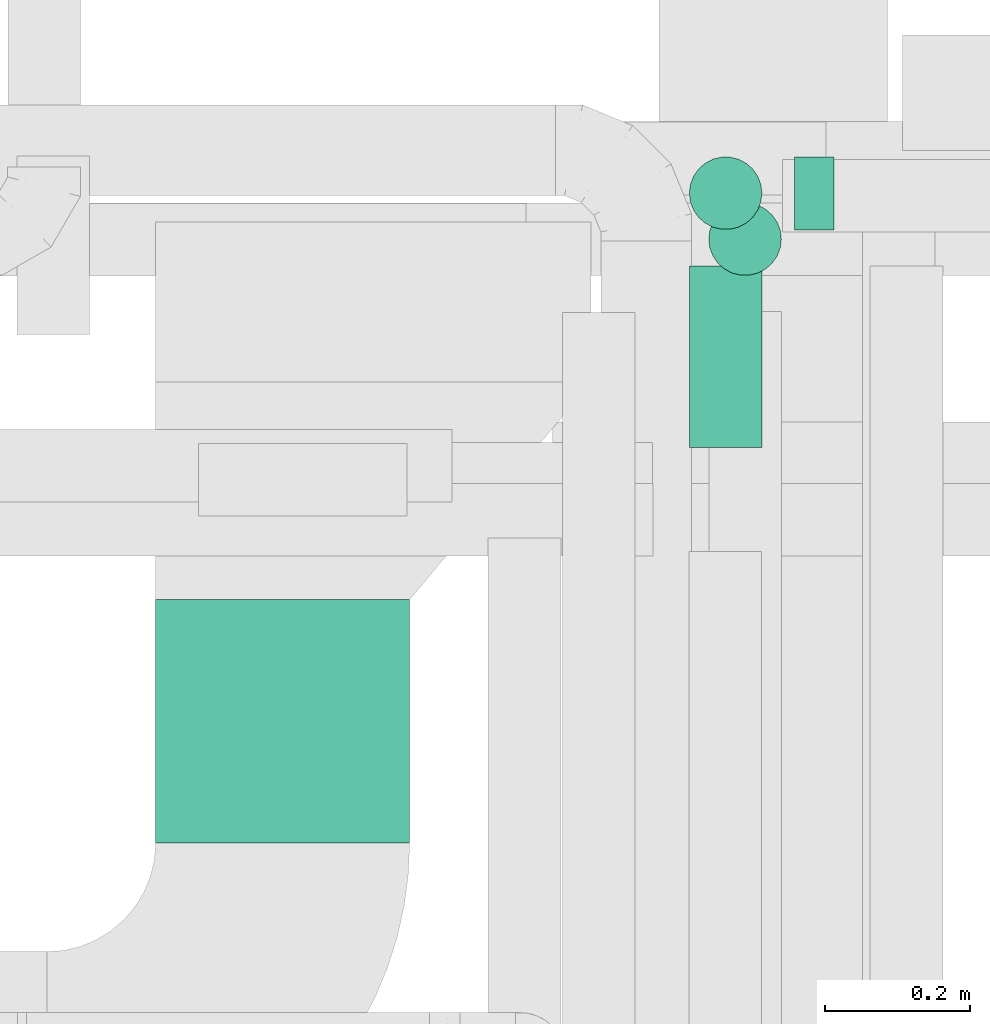
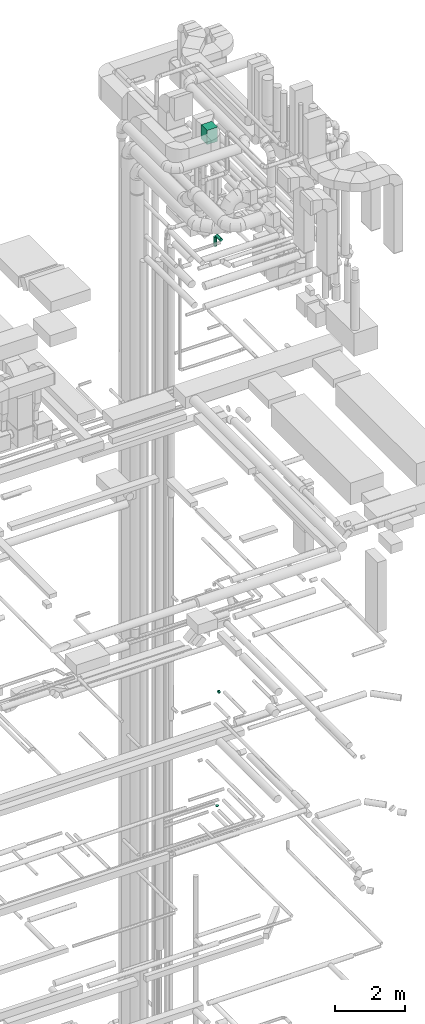
# One storey, part 266 of 337: 5 flow segments.
"""IFC2X3 building model written with IfcOpenShell, lengths in millimetres."""

import ifcopenshell
import ifcopenshell.guid

model = None  # the IFC model being written
_history = None  # IfcOwnerHistory: only IFC2X3 demands one
_inside = {}  # id of a spatial element -> (the spatial element, [elements in it])
_under = {}  # id of a project, library or spatial element -> (it, [spatial elements below it])
_declared = {}  # id of a project -> (the project, [libraries it declares])
_typed = {}  # id of a type object -> (the type object, [elements of that type])
_made_of = {}  # id of a material, layer set ... -> (it, [elements and type objects made of it])


def new_model(schema):
    """Start an empty IFC model of exactly this schema.

    Asked for "IFC4X3", IfcOpenShell would pick the latest addendum, in which some entities
    have other attributes; the version numbers below select the first issue.
    IFC2X3 requires an IfcOwnerHistory on every rooted entity: one is made here for all.
    """
    global model, _history
    if schema == "IFC4X3":
        model = ifcopenshell.file(schema_version=(4, 3, 0, 0))
    else:
        model = ifcopenshell.file(schema=schema)
    _inside.clear()
    _under.clear()
    _declared.clear()
    _typed.clear()
    _made_of.clear()
    _history = None
    if model.schema == "IFC2X3":
        org = make("IfcOrganization", Name="unknown")
        user = make(
            "IfcPersonAndOrganization",
            ThePerson=make("IfcPerson", FamilyName="unknown"),
            TheOrganization=org,
        )
        app = make(
            "IfcApplication",
            ApplicationDeveloper=org,
            Version="unknown",
            ApplicationFullName="unknown",
            ApplicationIdentifier="unknown",
        )
        _history = make(
            "IfcOwnerHistory",
            OwningUser=user,
            OwningApplication=app,
            ChangeAction="ADDED",
            CreationDate=0,
        )
    return model


def make(cls, **values):
    """One entity of the class cls with the attributes given. An attribute that is None is left unset."""
    return model.create_entity(
        cls, **{name: value for name, value in values.items() if value is not None}
    )


def entity(cls, *values):
    """Any entity or typed value of the class cls, its attributes in the order of the schema. None: left unset."""
    e = model.create_entity(cls)
    for i, value in enumerate(values):
        if value is not None:
            e[i] = value
    return e


def rooted(cls, **values):
    """An entity with a GlobalId (a new one), such as an element, a storey or a relation."""
    return make(cls, GlobalId=ifcopenshell.guid.new(), OwnerHistory=_history, **values)


def si_unit(unit_type, name, prefix=None):
    """IfcSIUnit, for example si_unit("LENGTHUNIT", "METRE", prefix="MILLI")."""
    return make("IfcSIUnit", UnitType=unit_type, Prefix=prefix, Name=name)


def converted_unit(unit_type, name, factor, base, dimensions=None, offset=None):
    """IfcConversionBasedUnit, such as the inch: factor (a typed value) times the base unit."""
    return make(
        "IfcConversionBasedUnit"
        if offset is None
        else "IfcConversionBasedUnitWithOffset",
        ConversionOffset=offset,
        Dimensions=None
        if dimensions is None
        else entity("IfcDimensionalExponents", *dimensions),
        UnitType=unit_type,
        Name=name,
        ConversionFactor=make(
            "IfcMeasureWithUnit", ValueComponent=factor, UnitComponent=base
        ),
    )


def derived_unit(unit_type, elements):
    """IfcDerivedUnit: a product of units, each with its exponent."""
    return make(
        "IfcDerivedUnit",
        Elements=[
            make("IfcDerivedUnitElement", Unit=unit, Exponent=power)
            for unit, power in elements
        ],
        UnitType=unit_type,
    )


def assignment(units):
    """IfcUnitAssignment: the units of a project."""
    return None if units is None else make("IfcUnitAssignment", Units=units)


def point(xyz):
    """IfcCartesianPoint."""
    return None if xyz is None else make("IfcCartesianPoint", Coordinates=xyz)


def direction(xyz):
    """IfcDirection."""
    return None if xyz is None else make("IfcDirection", DirectionRatios=xyz)


def frame(location, z_axis=None, x_axis=None):
    """IfcAxis2Placement3D, a coordinate frame: its origin and axes. An axis left out is left unset."""
    return make(
        "IfcAxis2Placement3D",
        Location=point(location),
        Axis=direction(z_axis),
        RefDirection=direction(x_axis),
    )


def frame_2d(location, x_axis=None):
    """IfcAxis2Placement2D, a coordinate frame in the plane: its origin and x axis."""
    return make(
        "IfcAxis2Placement2D", Location=point(location), RefDirection=direction(x_axis)
    )


def origin():
    """The frame at (0, 0, 0) with its axes left unset."""
    return frame((0.0, 0.0, 0.0))


def origin_2d_with_axis():
    """The frame at (0, 0) in the plane with the x axis (1, 0) written out."""
    return frame_2d((0.0, 0.0), x_axis=(1.0, 0.0))


def place(relative_to, where):
    """IfcLocalPlacement: puts the frame where relative to a parent placement (None: the world)."""
    return make(
        "IfcLocalPlacement", PlacementRelTo=relative_to, RelativePlacement=where
    )


def context(
    kind, dimensions, precision=None, world=None, true_north=None, identifier=None
):
    """IfcGeometricRepresentationContext, for example the 3D "Model" context."""
    return make(
        "IfcGeometricRepresentationContext",
        ContextIdentifier=identifier,
        ContextType=kind,
        CoordinateSpaceDimension=dimensions,
        Precision=precision,
        WorldCoordinateSystem=world,
        TrueNorth=true_north,
    )


def subcontext(parent, identifier, kind, view, scale=None):
    """IfcGeometricRepresentationSubContext, for example "Body" below "Model"."""
    return make(
        "IfcGeometricRepresentationSubContext",
        ContextIdentifier=identifier,
        ContextType=kind,
        ParentContext=parent,
        TargetScale=scale,
        TargetView=view,
    )


def project(units=None, contexts=None):
    """IfcProject with its units and contexts."""
    return rooted(
        "IfcProject",
        Name="project",
        RepresentationContexts=contexts,
        UnitsInContext=assignment(units),
    )


def spatial(cls, under=None, at=None, **own):
    """A site, building, storey or space (cls), placed at a placement, below another one or the project."""
    s = rooted(cls, ObjectPlacement=at, **own)
    if under is not None:
        _under.setdefault(under.id(), (under, []))[1].append(s)
    return s


def profile(cls, at=None, kind="AREA", **sizes):
    """A parametric profile (cls). Its sizes go by their IFC names, for example OverallWidth=200.0."""
    return make(cls, ProfileType=kind, Position=at, **sizes)


def rectangle(**sizes):
    """IfcRectangleProfileDef."""
    return profile("IfcRectangleProfileDef", **sizes)


def circle(**sizes):
    """IfcCircleProfileDef."""
    return profile("IfcCircleProfileDef", **sizes)


def extrude(swept, where, along, depth):
    """IfcExtrudedAreaSolid: the profile swept, set in the frame where, extruded along a direction by depth."""
    return make(
        "IfcExtrudedAreaSolid",
        SweptArea=swept,
        Position=where,
        ExtrudedDirection=direction(along),
        Depth=depth,
    )


def shape(context_of_items, identifier, shape_type, items):
    """IfcShapeRepresentation: the items that make up one representation, for example the "Body"."""
    return make(
        "IfcShapeRepresentation",
        ContextOfItems=context_of_items,
        RepresentationIdentifier=identifier,
        RepresentationType=shape_type,
        Items=items,
    )


def made_of(thing, what):
    """Note that an element or type object is made of a material, layer set ...; save() writes the relation."""
    if what is not None:
        _made_of.setdefault(what.id(), (what, []))[1].append(thing)
    return thing


def type_object(cls, material=None, **own):
    """A type object (cls), such as IfcWallType, which elements share."""
    return made_of(rooted(cls, **own), material)


def element(
    cls,
    number,
    at=None,
    inside=None,
    cuts=None,
    type_object=None,
    material=None,
    context=None,
    identifier="Body",
    shape_type=None,
    held_by="IfcProductDefinitionShape",
    body=None,
    shapes=None,
    **own,
):
    """One element of the class cls, such as IfcWall. Its Tag is "e" and its number.

    at: its placement. inside: the storey or other place that contains it. cuts: it is an
    opening in that element (IfcRelVoidsElement). A single representation is given by context,
    identifier, shape_type and body (its items); several are given by shapes. held_by: the class
    of the entity that holds the representations. save() writes the other relations.
    """
    e = rooted(cls, Tag="e%d" % number, ObjectPlacement=at, **own)
    if body is not None:
        shapes = [shape(context, identifier, shape_type, body)]
    if shapes is not None:
        e.Representation = make(held_by, Representations=shapes)
    if inside is not None:
        _inside.setdefault(inside.id(), (inside, []))[1].append(e)
    if cuts is not None:
        rooted(
            "IfcRelVoidsElement", RelatingBuildingElement=cuts, RelatedOpeningElement=e
        )
    if type_object is not None:
        _typed.setdefault(type_object.id(), (type_object, []))[1].append(e)
    return made_of(e, material)


def aggregate(whole, parts):
    """IfcRelAggregates: a whole, such as a stair, and the parts it consists of."""
    return rooted("IfcRelAggregates", RelatingObject=whole, RelatedObjects=parts)


def save(model, path):
    """Write the relations noted so far, then the file.

    IfcRelAggregates (storeys below a building ...), IfcRelContainedInSpatialStructure (elements
    in a storey), IfcRelDefinesByType, IfcRelAssociatesMaterial and IfcRelDeclares: one each for
    every whole, place, type object, material and project.
    """
    for whole, parts in _under.values():
        aggregate(whole, parts)
    for where, things in _inside.values():
        rooted(
            "IfcRelContainedInSpatialStructure",
            RelatedElements=things,
            RelatingStructure=where,
        )
    for kind, things in _typed.values():
        rooted("IfcRelDefinesByType", RelatedObjects=things, RelatingType=kind)
    for what, things in _made_of.values():
        rooted("IfcRelAssociatesMaterial", RelatedObjects=things, RelatingMaterial=what)
    for by, libraries in _declared.values():
        rooted("IfcRelDeclares", RelatingContext=by, RelatedDefinitions=libraries)
    model.write(path)


model = new_model("IFC2X3")

# Units and contexts
model_context = context("Model", 3, precision=0.01, world=origin(), true_north=direction((6.12303176911189e-17, 1.0)))
body_context = subcontext(model_context, "Body", "Model", "MODEL_VIEW")
ifc_project = project(units=[si_unit("LENGTHUNIT", "METRE", prefix="MILLI"), si_unit("AREAUNIT", "SQUARE_METRE"), si_unit("VOLUMEUNIT", "CUBIC_METRE"), converted_unit("PLANEANGLEUNIT", "DEGREE", entity("IfcRatioMeasure", 0.0174532925199433), si_unit("PLANEANGLEUNIT", "RADIAN"), dimensions=[0, 0, 0, 0, 0, 0, 0]), si_unit("MASSUNIT", "GRAM", prefix="KILO"), derived_unit("MASSDENSITYUNIT", [(si_unit("MASSUNIT", "GRAM", prefix="KILO"), 1), (si_unit("LENGTHUNIT", "METRE"), -3)]), derived_unit("MOMENTOFINERTIAUNIT", [(si_unit("LENGTHUNIT", "METRE"), 4)]), si_unit("TIMEUNIT", "SECOND"), si_unit("FREQUENCYUNIT", "HERTZ"), si_unit("THERMODYNAMICTEMPERATUREUNIT", "DEGREE_CELSIUS"), derived_unit("THERMALTRANSMITTANCEUNIT", [(si_unit("MASSUNIT", "GRAM", prefix="KILO"), 1), (si_unit("THERMODYNAMICTEMPERATUREUNIT", "KELVIN"), -1), (si_unit("TIMEUNIT", "SECOND"), -3)]), derived_unit("VOLUMETRICFLOWRATEUNIT", [(si_unit("LENGTHUNIT", "METRE"), 3), (si_unit("TIMEUNIT", "SECOND"), -1)]), derived_unit("MASSFLOWRATEUNIT", [(si_unit("MASSUNIT", "GRAM", prefix="KILO"), 1), (si_unit("TIMEUNIT", "SECOND"), -1)]), derived_unit("ROTATIONALFREQUENCYUNIT", [(si_unit("TIMEUNIT", "SECOND"), -1)]), si_unit("ELECTRICCURRENTUNIT", "AMPERE"), si_unit("ELECTRICVOLTAGEUNIT", "VOLT"), si_unit("POWERUNIT", "WATT"), si_unit("FORCEUNIT", "NEWTON", prefix="KILO"), si_unit("ILLUMINANCEUNIT", "LUX"), si_unit("LUMINOUSFLUXUNIT", "LUMEN"), si_unit("LUMINOUSINTENSITYUNIT", "CANDELA"), derived_unit("USERDEFINED", [(si_unit("MASSUNIT", "GRAM", prefix="KILO"), -1), (si_unit("LENGTHUNIT", "METRE"), -2), (si_unit("TIMEUNIT", "SECOND"), 3), (si_unit("LUMINOUSFLUXUNIT", "LUMEN"), 1)]), derived_unit("LINEARVELOCITYUNIT", [(si_unit("LENGTHUNIT", "METRE"), 1), (si_unit("TIMEUNIT", "SECOND"), -1)]), si_unit("PRESSUREUNIT", "PASCAL"), derived_unit("USERDEFINED", [(si_unit("LENGTHUNIT", "METRE"), -2), (si_unit("MASSUNIT", "GRAM", prefix="KILO"), 1), (si_unit("TIMEUNIT", "SECOND"), -2)]), derived_unit("LINEARFORCEUNIT", [(si_unit("MASSUNIT", "GRAM", prefix="KILO"), 1), (si_unit("LENGTHUNIT", "METRE"), 1), (si_unit("TIMEUNIT", "SECOND"), -2), (si_unit("LENGTHUNIT", "METRE"), -1)]), derived_unit("PLANARFORCEUNIT", [(si_unit("MASSUNIT", "GRAM", prefix="KILO"), 1), (si_unit("LENGTHUNIT", "METRE"), 1), (si_unit("TIMEUNIT", "SECOND"), -2), (si_unit("LENGTHUNIT", "METRE"), -2)])], contexts=[model_context])

# Site, building, storey
site_placement = place(None, origin())
site = spatial("IfcSite", under=ifc_project, at=site_placement, CompositionType="ELEMENT")
building_placement = place(site_placement, origin())
building = spatial("IfcBuilding", under=site, at=building_placement, CompositionType="ELEMENT")
storey_placement = place(building_placement, origin())
storey = spatial("IfcBuildingStorey", under=building, at=storey_placement, CompositionType="ELEMENT", Elevation=0.0)

# Flow segments
duct_segment_type_1 = type_object("IfcDuctSegmentType", PredefinedType="NOTDEFINED")
flow_segment_1_placement = place(storey_placement, frame((69255.37, 10723.58, 35280.0)))
element("IfcFlowSegment", 1, at=flow_segment_1_placement, inside=storey, type_object=duct_segment_type_1, context=body_context, shape_type="SweptSolid", body=[
    extrude(rectangle(XDim=334.937196376933, YDim=349.999999999998, at=origin_2d_with_axis()), frame((175.0, 167.47, 0.0), z_axis=(0.0, 0.0, 1.0), x_axis=(0.0, -1.0, 0.0)), (0.0, 0.0, 1.0), 499.999999999999),
])
duct_segment_type_2 = type_object("IfcDuctSegmentType", PredefinedType="NOTDEFINED")
flow_segment_2_placement = place(storey_placement, frame((70135.19, 11566.5, 15248.4)))
element("IfcFlowSegment", 2, at=flow_segment_2_placement, inside=storey, type_object=duct_segment_type_2, context=body_context, shape_type="SweptSolid", body=[
    extrude(circle(Radius=50.0, at=origin_2d_with_axis()), frame((0.0, 51.6, 51.6), z_axis=(1.0, 0.0, 0.0), x_axis=(0.0, 1.0, 0.0)), (0.0, 0.0, 1.0), 54.5208499999747),
])
flow_segment_3_placement = place(storey_placement, frame((70015.69, 11503.66, 11380.0)))
element("IfcFlowSegment", 3, at=flow_segment_3_placement, inside=storey, type_object=duct_segment_type_2, context=body_context, shape_type="SweptSolid", body=[
    extrude(circle(Radius=50.0, at=origin_2d_with_axis()), frame((51.6, 51.6, 0.0)), (0.0, 0.0, 1.0), 20.0000000000171),
])
flow_segment_4_placement = place(storey_placement, frame((69988.94, 11268.54, 31298.4)))
element("IfcFlowSegment", 4, at=flow_segment_4_placement, inside=storey, type_object=duct_segment_type_2, context=body_context, shape_type="SweptSolid", body=[
    extrude(circle(Radius=50.0, at=origin_2d_with_axis()), frame((51.6, 0.0, 51.6), z_axis=(0.0, 1.0, 0.0), x_axis=(1.0, 0.0, 0.0)), (0.0, 0.0, 1.0), 250.000000000002),
])
flow_segment_5_placement = place(storey_placement, frame((69988.94, 11566.95, 30940.0)))
element("IfcFlowSegment", 5, at=flow_segment_5_placement, inside=storey, type_object=duct_segment_type_2, context=body_context, shape_type="SweptSolid", body=[
    extrude(circle(Radius=50.0, at=origin_2d_with_axis()), frame((51.6, 51.6, 0.0), z_axis=(0.0, 0.0, 1.0), x_axis=(-1.0, 0.0, 0.0)), (0.0, 0.0, 1.0), 310.00000000002),
])

save(model, "model.ifc")
